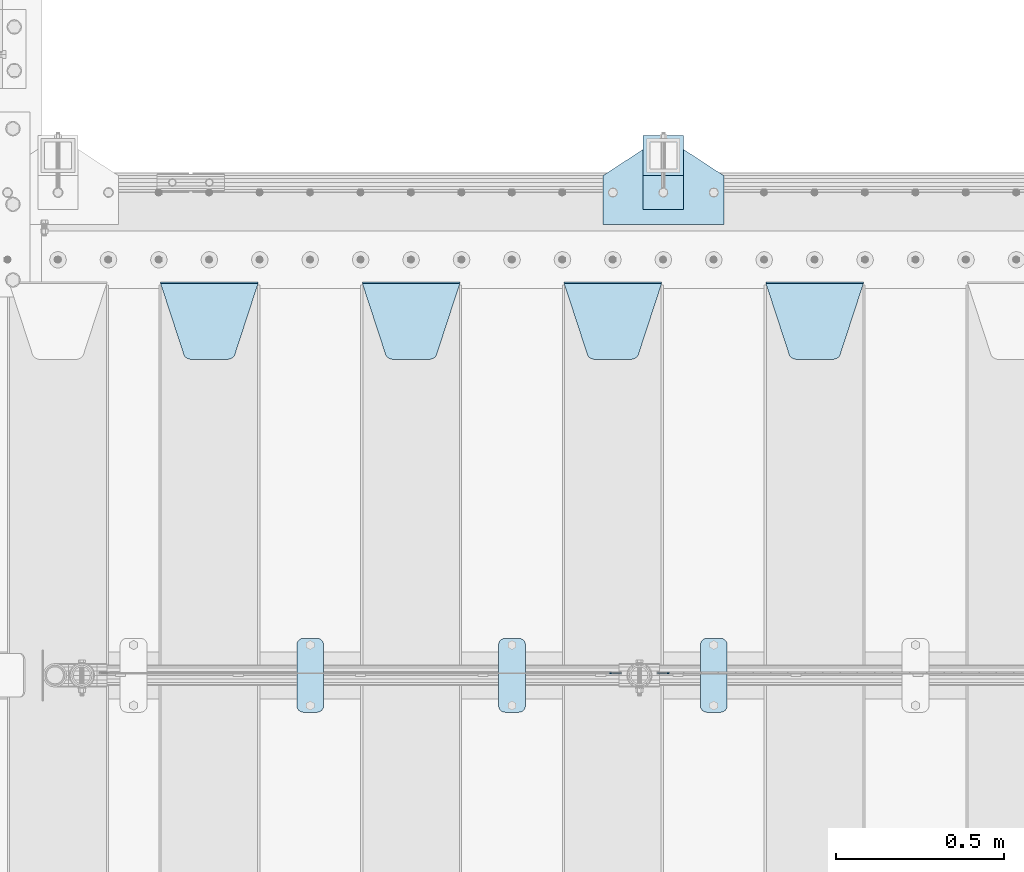
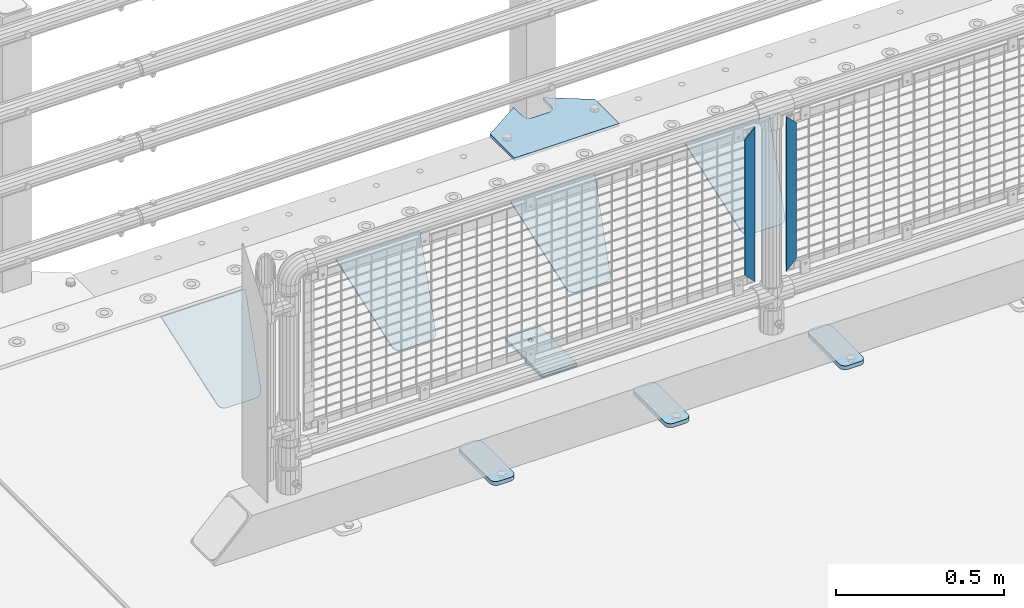
# One storey, part 194 of 219: 12 plates.
"""IFC2X3 building model written with IfcOpenShell, lengths in millimetres."""

from ifc_helpers import new_model, si_unit, frame, origin_with_axes, place, context, subcontext, project, spatial, faceted_brep, material, type_object, element, save


model = new_model("IFC2X3")

# Units and contexts
model_context = context("Model", 3, precision=1e-05, world=origin_with_axes())
body_context = subcontext(model_context, "Body", "Model", "MODEL_VIEW")
ifc_project = project(units=[si_unit("LENGTHUNIT", "METRE", prefix="MILLI"), si_unit("AREAUNIT", "SQUARE_METRE"), si_unit("VOLUMEUNIT", "CUBIC_METRE"), si_unit("MASSUNIT", "GRAM", prefix="KILO"), si_unit("TIMEUNIT", "SECOND"), si_unit("PLANEANGLEUNIT", "RADIAN"), si_unit("SOLIDANGLEUNIT", "STERADIAN"), si_unit("THERMODYNAMICTEMPERATUREUNIT", "DEGREE_CELSIUS"), si_unit("LUMINOUSINTENSITYUNIT", "LUMEN")], contexts=[model_context])

# Site, building, storey
site_placement = place(None, origin_with_axes())
site = spatial("IfcSite", under=ifc_project, at=site_placement, CompositionType="ELEMENT")
building_placement = place(site_placement, origin_with_axes())
building = spatial("IfcBuilding", under=site, at=building_placement, Name="Standard", CompositionType="ELEMENT")
storey_placement = place(building_placement, origin_with_axes())
storey = spatial("IfcBuildingStorey", under=building, at=storey_placement, Name="Undefined", CompositionType="ELEMENT", Elevation=0.0)

# Plates
ifc_material_1 = material(Name="STEEL/S355N")
plate_type_1 = type_object("IfcPlateType", PredefinedType="NOTDEFINED")
plate_1_placement = place(storey_placement, frame((2655.0, 32831.767766956, -1.76776695296758), z_axis=(0.0, -0.707106781186547, -0.707106781186548), x_axis=(1.0, 0.0, 0.0)))
element("IfcPlate", 1, at=plate_1_placement, inside=storey, type_object=plate_type_1, material=ifc_material_1, context=body_context, shape_type="Brep", body=[
    faceted_brep([(0.0, -2.5, 0.0), (69.345504679477, -2.5, 300.171731424834), (69.345504679477, 2.49999999999636, 300.171731424831), (0.0, 2.5, 0.0), (70.9274061199576, -2.50000000000364, 304.8974424154), (70.9274061199576, 2.49999999999636, 304.8974424154), (73.3818627772307, -2.50000000000364, 309.234538108532), (73.3818627772307, 2.49999999999636, 309.234538108532), (76.6187032999569, -2.50000000000364, 313.023683126106), (76.6187032999569, 2.49999999999636, 313.023683126106), (80.5190132704993, -2.50000000000364, 316.125672595372), (80.5190132704993, 2.49999999999636, 316.125672595372), (84.9395038596831, -2.50000000000364, 318.426546230476), (84.9395038596831, 2.5, 318.426546230479), (89.7177759439237, -2.50000000000364, 319.841774983277), (89.7177759439237, 2.5, 319.841774983281), (94.6782862926502, -2.50000000000364, 320.319366455078), (94.6782862926502, 2.49999999999636, 320.319366455078), (195.32171370735, -2.50000000000364, 320.319366455078), (195.32171370735, 2.49999999999636, 320.319366455078), (200.282224056076, -2.50000000000364, 319.841774983277), (200.282224056076, 2.5, 319.841774983281), (205.060496140317, -2.50000000000364, 318.426546230476), (205.060496140317, 2.49999999999636, 318.426546230476), (209.480986729501, -2.50000000000364, 316.125672595372), (209.480986729501, 2.49999999999636, 316.125672595372), (213.381296700043, -2.50000000000364, 313.023683126106), (213.381296700043, 2.49999999999272, 313.023683126106), (216.618137222769, -2.50000000000364, 309.234538108529), (216.618137222769, 2.49999999999636, 309.234538108525), (219.072593880042, -2.50000000000364, 304.8974424154), (219.072593880042, 2.49999999999636, 304.8974424154), (220.654495320523, -2.5, 300.171731424834), (220.654495320523, 2.49999999999636, 300.171731424831), (290.0, -2.50000000000364, 3.63797880709171e-12), (290.0, 2.49999999999636, 0.0)], [[[0, 1, 2, 3]], [[1, 4, 5, 2]], [[4, 6, 7, 5]], [[6, 8, 9, 7]], [[8, 10, 11, 9]], [[10, 12, 13, 11]], [[12, 14, 15, 13]], [[14, 16, 17, 15]], [[16, 18, 19, 17]], [[18, 20, 21, 19]], [[20, 22, 23, 21]], [[22, 24, 25, 23]], [[24, 26, 27, 25]], [[26, 28, 29, 27]], [[28, 30, 31, 29]], [[30, 32, 33, 31]], [[32, 34, 35, 33]], [[34, 0, 3, 35]], [[5, 7, 9, 11, 13, 15, 17, 19, 21, 23, 25, 27, 29, 31, 33, 35, 3, 2]], [[34, 32, 30, 28, 26, 24, 22, 20, 18, 16, 14, 12, 10, 8, 6, 4, 1, 0]]]),
])
plate_2_placement = place(storey_placement, frame((2055.0, 32831.767766956, -1.76776695296758), z_axis=(0.0, -0.707106781186547, -0.707106781186548), x_axis=(1.0, 0.0, 0.0)))
element("IfcPlate", 2, at=plate_2_placement, inside=storey, type_object=plate_type_1, material=ifc_material_1, context=body_context, shape_type="Brep", body=[
    faceted_brep([(0.0, -2.5, 0.0), (69.345504679477, -2.5, 300.171731424834), (69.345504679477, 2.49999999999636, 300.171731424831), (0.0, 2.5, 0.0), (70.9274061199576, -2.50000000000364, 304.8974424154), (70.9274061199576, 2.49999999999636, 304.8974424154), (73.3818627772307, -2.50000000000364, 309.234538108532), (73.3818627772307, 2.49999999999636, 309.234538108532), (76.6187032999569, -2.50000000000364, 313.023683126106), (76.6187032999569, 2.49999999999636, 313.023683126106), (80.5190132704993, -2.50000000000364, 316.125672595372), (80.5190132704993, 2.49999999999636, 316.125672595372), (84.9395038596831, -2.50000000000364, 318.426546230476), (84.9395038596831, 2.5, 318.426546230479), (89.7177759439237, -2.50000000000364, 319.841774983277), (89.7177759439237, 2.5, 319.841774983281), (94.6782862926502, -2.50000000000364, 320.319366455078), (94.6782862926502, 2.49999999999636, 320.319366455078), (195.32171370735, -2.50000000000364, 320.319366455078), (195.32171370735, 2.49999999999636, 320.319366455078), (200.282224056076, -2.50000000000364, 319.841774983277), (200.282224056076, 2.5, 319.841774983281), (205.060496140317, -2.50000000000364, 318.426546230476), (205.060496140317, 2.49999999999636, 318.426546230476), (209.480986729501, -2.50000000000364, 316.125672595372), (209.480986729501, 2.49999999999636, 316.125672595372), (213.381296700043, -2.50000000000364, 313.023683126106), (213.381296700043, 2.49999999999272, 313.023683126106), (216.618137222769, -2.50000000000364, 309.234538108529), (216.618137222769, 2.49999999999636, 309.234538108525), (219.072593880042, -2.50000000000364, 304.8974424154), (219.072593880042, 2.49999999999636, 304.8974424154), (220.654495320523, -2.5, 300.171731424834), (220.654495320523, 2.49999999999636, 300.171731424831), (290.0, -2.50000000000364, 3.63797880709171e-12), (290.0, 2.49999999999636, 0.0)], [[[0, 1, 2, 3]], [[1, 4, 5, 2]], [[4, 6, 7, 5]], [[6, 8, 9, 7]], [[8, 10, 11, 9]], [[10, 12, 13, 11]], [[12, 14, 15, 13]], [[14, 16, 17, 15]], [[16, 18, 19, 17]], [[18, 20, 21, 19]], [[20, 22, 23, 21]], [[22, 24, 25, 23]], [[24, 26, 27, 25]], [[26, 28, 29, 27]], [[28, 30, 31, 29]], [[30, 32, 33, 31]], [[32, 34, 35, 33]], [[34, 0, 3, 35]], [[5, 7, 9, 11, 13, 15, 17, 19, 21, 23, 25, 27, 29, 31, 33, 35, 3, 2]], [[34, 32, 30, 28, 26, 24, 22, 20, 18, 16, 14, 12, 10, 8, 6, 4, 1, 0]]]),
])
plate_3_placement = place(storey_placement, frame((1455.0, 32831.767766956, -1.76776695296758), z_axis=(0.0, -0.707106781186547, -0.707106781186548), x_axis=(1.0, 0.0, 0.0)))
element("IfcPlate", 3, at=plate_3_placement, inside=storey, type_object=plate_type_1, material=ifc_material_1, context=body_context, shape_type="Brep", body=[
    faceted_brep([(0.0, -2.5, 0.0), (69.345504679477, -2.5, 300.171731424834), (69.345504679477, 2.49999999999636, 300.171731424831), (0.0, 2.5, 0.0), (70.9274061199576, -2.50000000000364, 304.8974424154), (70.9274061199576, 2.49999999999636, 304.8974424154), (73.3818627772307, -2.50000000000364, 309.234538108532), (73.3818627772307, 2.49999999999636, 309.234538108532), (76.6187032999569, -2.50000000000364, 313.023683126106), (76.6187032999569, 2.49999999999636, 313.023683126106), (80.5190132704993, -2.50000000000364, 316.125672595372), (80.5190132704993, 2.49999999999636, 316.125672595372), (84.9395038596831, -2.50000000000364, 318.426546230476), (84.9395038596831, 2.5, 318.426546230479), (89.7177759439237, -2.50000000000364, 319.841774983277), (89.7177759439237, 2.5, 319.841774983281), (94.6782862926502, -2.50000000000364, 320.319366455078), (94.6782862926502, 2.49999999999636, 320.319366455078), (195.32171370735, -2.50000000000364, 320.319366455078), (195.32171370735, 2.49999999999636, 320.319366455078), (200.282224056076, -2.50000000000364, 319.841774983277), (200.282224056076, 2.5, 319.841774983281), (205.060496140317, -2.50000000000364, 318.426546230476), (205.060496140317, 2.49999999999636, 318.426546230476), (209.480986729501, -2.50000000000364, 316.125672595372), (209.480986729501, 2.49999999999636, 316.125672595372), (213.381296700043, -2.50000000000364, 313.023683126106), (213.381296700043, 2.49999999999272, 313.023683126106), (216.618137222769, -2.50000000000364, 309.234538108529), (216.618137222769, 2.49999999999636, 309.234538108525), (219.072593880042, -2.50000000000364, 304.8974424154), (219.072593880042, 2.49999999999636, 304.8974424154), (220.654495320523, -2.5, 300.171731424834), (220.654495320523, 2.49999999999636, 300.171731424831), (290.0, -2.50000000000364, 3.63797880709171e-12), (290.0, 2.49999999999636, 0.0)], [[[0, 1, 2, 3]], [[1, 4, 5, 2]], [[4, 6, 7, 5]], [[6, 8, 9, 7]], [[8, 10, 11, 9]], [[10, 12, 13, 11]], [[12, 14, 15, 13]], [[14, 16, 17, 15]], [[16, 18, 19, 17]], [[18, 20, 21, 19]], [[20, 22, 23, 21]], [[22, 24, 25, 23]], [[24, 26, 27, 25]], [[26, 28, 29, 27]], [[28, 30, 31, 29]], [[30, 32, 33, 31]], [[32, 34, 35, 33]], [[34, 0, 3, 35]], [[5, 7, 9, 11, 13, 15, 17, 19, 21, 23, 25, 27, 29, 31, 33, 35, 3, 2]], [[34, 32, 30, 28, 26, 24, 22, 20, 18, 16, 14, 12, 10, 8, 6, 4, 1, 0]]]),
])
plate_4_placement = place(storey_placement, frame((855.0, 32831.767766956, -1.76776695296758), z_axis=(0.0, -0.707106781186547, -0.707106781186548), x_axis=(1.0, 0.0, 0.0)))
element("IfcPlate", 4, at=plate_4_placement, inside=storey, type_object=plate_type_1, material=ifc_material_1, context=body_context, shape_type="Brep", body=[
    faceted_brep([(0.0, -2.5, 0.0), (69.345504679477, -2.5, 300.171731424834), (69.345504679477, 2.49999999999636, 300.171731424831), (0.0, 2.5, 0.0), (70.9274061199576, -2.50000000000364, 304.8974424154), (70.9274061199576, 2.49999999999636, 304.8974424154), (73.3818627772307, -2.50000000000364, 309.234538108532), (73.3818627772307, 2.49999999999636, 309.234538108532), (76.6187032999569, -2.50000000000364, 313.023683126106), (76.6187032999569, 2.49999999999636, 313.023683126106), (80.5190132704993, -2.50000000000364, 316.125672595372), (80.5190132704993, 2.49999999999636, 316.125672595372), (84.9395038596831, -2.50000000000364, 318.426546230476), (84.9395038596831, 2.5, 318.426546230479), (89.7177759439237, -2.50000000000364, 319.841774983277), (89.7177759439237, 2.5, 319.841774983281), (94.6782862926502, -2.50000000000364, 320.319366455078), (94.6782862926502, 2.49999999999636, 320.319366455078), (195.32171370735, -2.50000000000364, 320.319366455078), (195.32171370735, 2.49999999999636, 320.319366455078), (200.282224056076, -2.50000000000364, 319.841774983277), (200.282224056076, 2.5, 319.841774983281), (205.060496140317, -2.50000000000364, 318.426546230476), (205.060496140317, 2.49999999999636, 318.426546230476), (209.480986729501, -2.50000000000364, 316.125672595372), (209.480986729501, 2.49999999999636, 316.125672595372), (213.381296700043, -2.50000000000364, 313.023683126106), (213.381296700043, 2.49999999999272, 313.023683126106), (216.618137222769, -2.50000000000364, 309.234538108529), (216.618137222769, 2.49999999999636, 309.234538108525), (219.072593880042, -2.50000000000364, 304.8974424154), (219.072593880042, 2.49999999999636, 304.8974424154), (220.654495320523, -2.5, 300.171731424834), (220.654495320523, 2.49999999999636, 300.171731424831), (290.0, -2.50000000000364, 3.63797880709171e-12), (290.0, 2.49999999999636, 0.0)], [[[0, 1, 2, 3]], [[1, 4, 5, 2]], [[4, 6, 7, 5]], [[6, 8, 9, 7]], [[8, 10, 11, 9]], [[10, 12, 13, 11]], [[12, 14, 15, 13]], [[14, 16, 17, 15]], [[16, 18, 19, 17]], [[18, 20, 21, 19]], [[20, 22, 23, 21]], [[22, 24, 25, 23]], [[24, 26, 27, 25]], [[26, 28, 29, 27]], [[28, 30, 31, 29]], [[30, 32, 33, 31]], [[32, 34, 35, 33]], [[34, 0, 3, 35]], [[5, 7, 9, 11, 13, 15, 17, 19, 21, 23, 25, 27, 29, 31, 33, 35, 3, 2]], [[34, 32, 30, 28, 26, 24, 22, 20, 18, 16, 14, 12, 10, 8, 6, 4, 1, 0]]]),
])
ifc_material_2 = material(Name="Misc_Undefined")
plate_type_2 = type_object("IfcPlateType", PredefinedType="NOTDEFINED")
plate_5_placement = place(storey_placement, frame((2367.50971354097, 31670.5, 879.519963133601), z_axis=(-0.707008801899319, 0.0, -0.707204746899291), x_axis=(-0.707204746899285, 0.0, 0.707008801899324)))
element("IfcPlate", 5, at=plate_5_placement, inside=storey, type_object=plate_type_2, material=ifc_material_2, context=body_context, shape_type="Brep", body=[
    faceted_brep([(0.0, -1.5, -5.6843418860808e-14), (-348.552185058593, -1.5, 348.655029296875), (-348.552185058593, 1.5, 348.655029296875), (0.0, 1.5, -5.6843418860808e-14), (-348.544891357421, -1.5, 398.152496337892), (-348.544891357421, 1.5, 398.152496337892), (49.5043945312482, -1.5, 7.6397554948926e-11), (49.5043945312482, 1.5, 7.6397554948926e-11)], [[[0, 1, 2, 3]], [[1, 4, 5, 2]], [[4, 6, 7, 5]], [[6, 0, 3, 7]], [[5, 7, 3, 2]], [[6, 4, 1, 0]]]),
])
plate_6_placement = place(storey_placement, frame((2190.49968748361, 31670.5, 879.52), z_axis=(0.707103624179499, 0.0, -0.707109938179501), x_axis=(0.707109938179499, 0.0, 0.707103624179502)))
element("IfcPlate", 6, at=plate_6_placement, inside=storey, type_object=plate_type_2, material=ifc_material_2, context=body_context, shape_type="Brep", body=[
    faceted_brep([(0.0, -1.5, -5.6843418860808e-14), (-348.605163574219, -1.5, 348.602081298829), (-348.605163574219, 1.5, 348.602081298829), (0.0, 1.5, -5.6843418860808e-14), (-348.605163574217, -1.5, 398.0993347168), (-348.605163574217, 1.5, 398.0993347168), (49.4976959228516, -1.5, -1.0550138540566e-10), (49.4976959228516, 1.5, -1.0550138540566e-10)], [[[0, 1, 2, 3]], [[1, 4, 5, 2]], [[4, 6, 7, 5]], [[6, 0, 3, 7]], [[5, 7, 3, 2]], [[6, 4, 1, 0]]]),
])
ifc_material_3 = material(Name="STEEL/S355J2")
plate_type_3 = type_object("IfcPlateType", PredefinedType="NOTDEFINED")
plate_7_placement = place(storey_placement, frame((2460.0, 31774.5, 21.0199999999977), z_axis=(1.0, 0.0, 0.0), x_axis=(0.0, -1.0, 0.0)))
element("IfcPlate", 7, at=plate_7_placement, inside=storey, type_object=plate_type_3, material=ifc_material_3, context=body_context, shape_type="Brep", body=[
    faceted_brep([(0.0, -7.0, 20.0), (0.0, -7.0, 60.0), (0.0, 7.0, 60.0), (0.0, 7.0, 20.0), (0.384294391937146, -7.0, 63.9018064403226), (0.384294391937146, 7.0, 63.9018064403226), (1.52240934977453, -7.0, 67.6536686473009), (1.52240934977453, 7.0, 67.6536686473009), (3.37060775395003, -7.0, 71.1114046603925), (3.37060775395003, 7.0, 71.1114046603925), (5.8578643762703, -7.0, 74.1421356237315), (5.8578643762703, 7.0, 74.1421356237315), (8.88859533960931, -7.0, 76.6293922460518), (8.88859533960931, 7.0, 76.6293922460518), (12.3463313526991, -7.0, 78.4775906502255), (12.3463313526991, 7.0, 78.4775906502255), (16.0981935596792, -7.0, 79.6157056080647), (16.0981935596792, 7.0, 79.6157056080647), (20.0, -7.0, 80.0), (20.0, 7.0, 80.0), (200.0, -7.0, 80.0), (200.0, 7.0, 80.0), (203.901806440321, -7.0, 79.6157056080647), (203.901806440321, 7.0, 79.6157056080647), (207.653668647301, -7.0, 78.4775906502255), (207.653668647301, 7.0, 78.4775906502255), (211.111404660391, -7.0, 76.6293922460518), (211.111404660391, 7.0, 76.6293922460518), (214.14213562373, -7.0, 74.1421356237315), (214.14213562373, 7.0, 74.1421356237315), (216.62939224605, -7.0, 71.1114046603925), (216.62939224605, 7.0, 71.1114046603925), (218.477590650225, -7.0, 67.6536686473009), (218.477590650225, 7.0, 67.6536686473009), (219.615705608063, -7.0, 63.9018064403226), (219.615705608063, 7.0, 63.9018064403226), (220.0, -7.0, 60.0), (220.0, 7.0, 60.0), (220.0, -7.0, 20.0), (220.0, 7.0, 20.0), (219.615705608063, -7.0, 16.0981935596774), (219.615705608063, 7.0, 16.0981935596774), (218.477590650225, -7.0, 12.3463313526991), (218.477590650225, 7.0, 12.3463313526991), (216.62939224605, -7.0, 8.88859533960749), (216.62939224605, 7.0, 8.88859533960749), (214.14213562373, -7.0, 5.85786437626848), (214.14213562373, 7.0, 5.85786437626848), (211.111404660391, -7.0, 3.37060775394821), (211.111404660391, 7.0, 3.37060775394821), (207.653668647301, -7.0, 1.52240934977453), (207.653668647301, 7.0, 1.52240934977453), (203.901806440321, -7.0, 0.384294391935327), (203.901806440321, 7.0, 0.384294391935327), (200.0, -7.0, 0.0), (200.0, 7.0, 0.0), (20.0, -7.0, 0.0), (20.0, 7.0, 0.0), (16.0981935596792, -7.0, 0.384294391935327), (16.0981935596792, 7.0, 0.384294391935327), (12.3463313526991, -7.0, 1.52240934977453), (12.3463313526991, 7.0, 1.52240934977453), (8.88859533960931, -7.0, 3.37060775394821), (8.88859533960931, 7.0, 3.37060775394821), (5.8578643762703, -7.0, 5.85786437626848), (5.8578643762703, 7.0, 5.85786437626848), (3.37060775395003, -7.0, 8.88859533960749), (3.37060775395003, 7.0, 8.88859533960749), (1.52240934977453, -7.0, 12.3463313526991), (1.52240934977453, 7.0, 12.3463313526991), (0.384294391937146, -7.0, 16.0981935596774), (0.384294391937146, 7.0, 16.0981935596774)], [[[0, 1, 2, 3]], [[1, 4, 5, 2]], [[4, 6, 7, 5]], [[6, 8, 9, 7]], [[8, 10, 11, 9]], [[10, 12, 13, 11]], [[12, 14, 15, 13]], [[14, 16, 17, 15]], [[16, 18, 19, 17]], [[18, 20, 21, 19]], [[20, 22, 23, 21]], [[22, 24, 25, 23]], [[24, 26, 27, 25]], [[26, 28, 29, 27]], [[28, 30, 31, 29]], [[30, 32, 33, 31]], [[32, 34, 35, 33]], [[34, 36, 37, 35]], [[36, 38, 39, 37]], [[38, 40, 41, 39]], [[40, 42, 43, 41]], [[42, 44, 45, 43]], [[44, 46, 47, 45]], [[46, 48, 49, 47]], [[48, 50, 51, 49]], [[50, 52, 53, 51]], [[52, 54, 55, 53]], [[54, 56, 57, 55]], [[56, 58, 59, 57]], [[58, 60, 61, 59]], [[60, 62, 63, 61]], [[62, 64, 65, 63]], [[64, 66, 67, 65]], [[66, 68, 69, 67]], [[68, 70, 71, 69]], [[70, 0, 3, 71]], [[5, 7, 9, 11, 13, 15, 17, 19, 21, 23, 25, 27, 29, 31, 33, 35, 37, 39, 41, 43, 45, 47, 49, 51, 53, 55, 57, 59, 61, 63, 65, 67, 69, 71, 3, 2]], [[70, 68, 66, 64, 62, 60, 58, 56, 54, 52, 50, 48, 46, 44, 42, 40, 38, 36, 34, 32, 30, 28, 26, 24, 22, 20, 18, 16, 14, 12, 10, 8, 6, 4, 1, 0]]]),
])
plate_8_placement = place(storey_placement, frame((1860.0, 31774.5, 21.0199999999977), z_axis=(1.0, 0.0, 0.0), x_axis=(0.0, -1.0, 0.0)))
element("IfcPlate", 8, at=plate_8_placement, inside=storey, type_object=plate_type_3, material=ifc_material_3, context=body_context, shape_type="Brep", body=[
    faceted_brep([(0.0, -7.0, 20.0), (0.0, -7.0, 60.0), (0.0, 7.0, 60.0), (0.0, 7.0, 20.0), (0.384294391937146, -7.0, 63.9018064403226), (0.384294391937146, 7.0, 63.9018064403226), (1.52240934977453, -7.0, 67.6536686473009), (1.52240934977453, 7.0, 67.6536686473009), (3.37060775395003, -7.0, 71.1114046603925), (3.37060775395003, 7.0, 71.1114046603925), (5.8578643762703, -7.0, 74.1421356237315), (5.8578643762703, 7.0, 74.1421356237315), (8.88859533960931, -7.0, 76.6293922460518), (8.88859533960931, 7.0, 76.6293922460518), (12.3463313526991, -7.0, 78.4775906502255), (12.3463313526991, 7.0, 78.4775906502255), (16.0981935596792, -7.0, 79.6157056080647), (16.0981935596792, 7.0, 79.6157056080647), (20.0, -7.0, 80.0), (20.0, 7.0, 80.0), (200.0, -7.0, 80.0), (200.0, 7.0, 80.0), (203.901806440321, -7.0, 79.6157056080647), (203.901806440321, 7.0, 79.6157056080647), (207.653668647301, -7.0, 78.4775906502255), (207.653668647301, 7.0, 78.4775906502255), (211.111404660391, -7.0, 76.6293922460518), (211.111404660391, 7.0, 76.6293922460518), (214.14213562373, -7.0, 74.1421356237315), (214.14213562373, 7.0, 74.1421356237315), (216.62939224605, -7.0, 71.1114046603925), (216.62939224605, 7.0, 71.1114046603925), (218.477590650225, -7.0, 67.6536686473009), (218.477590650225, 7.0, 67.6536686473009), (219.615705608063, -7.0, 63.9018064403226), (219.615705608063, 7.0, 63.9018064403226), (220.0, -7.0, 60.0), (220.0, 7.0, 60.0), (220.0, -7.0, 20.0), (220.0, 7.0, 20.0), (219.615705608063, -7.0, 16.0981935596774), (219.615705608063, 7.0, 16.0981935596774), (218.477590650225, -7.0, 12.3463313526991), (218.477590650225, 7.0, 12.3463313526991), (216.62939224605, -7.0, 8.88859533960749), (216.62939224605, 7.0, 8.88859533960749), (214.14213562373, -7.0, 5.85786437626848), (214.14213562373, 7.0, 5.85786437626848), (211.111404660391, -7.0, 3.37060775394821), (211.111404660391, 7.0, 3.37060775394821), (207.653668647301, -7.0, 1.52240934977453), (207.653668647301, 7.0, 1.52240934977453), (203.901806440321, -7.0, 0.384294391935327), (203.901806440321, 7.0, 0.384294391935327), (200.0, -7.0, 0.0), (200.0, 7.0, 0.0), (20.0, -7.0, 0.0), (20.0, 7.0, 0.0), (16.0981935596792, -7.0, 0.384294391935327), (16.0981935596792, 7.0, 0.384294391935327), (12.3463313526991, -7.0, 1.52240934977453), (12.3463313526991, 7.0, 1.52240934977453), (8.88859533960931, -7.0, 3.37060775394821), (8.88859533960931, 7.0, 3.37060775394821), (5.8578643762703, -7.0, 5.85786437626848), (5.8578643762703, 7.0, 5.85786437626848), (3.37060775395003, -7.0, 8.88859533960749), (3.37060775395003, 7.0, 8.88859533960749), (1.52240934977453, -7.0, 12.3463313526991), (1.52240934977453, 7.0, 12.3463313526991), (0.384294391937146, -7.0, 16.0981935596774), (0.384294391937146, 7.0, 16.0981935596774)], [[[0, 1, 2, 3]], [[1, 4, 5, 2]], [[4, 6, 7, 5]], [[6, 8, 9, 7]], [[8, 10, 11, 9]], [[10, 12, 13, 11]], [[12, 14, 15, 13]], [[14, 16, 17, 15]], [[16, 18, 19, 17]], [[18, 20, 21, 19]], [[20, 22, 23, 21]], [[22, 24, 25, 23]], [[24, 26, 27, 25]], [[26, 28, 29, 27]], [[28, 30, 31, 29]], [[30, 32, 33, 31]], [[32, 34, 35, 33]], [[34, 36, 37, 35]], [[36, 38, 39, 37]], [[38, 40, 41, 39]], [[40, 42, 43, 41]], [[42, 44, 45, 43]], [[44, 46, 47, 45]], [[46, 48, 49, 47]], [[48, 50, 51, 49]], [[50, 52, 53, 51]], [[52, 54, 55, 53]], [[54, 56, 57, 55]], [[56, 58, 59, 57]], [[58, 60, 61, 59]], [[60, 62, 63, 61]], [[62, 64, 65, 63]], [[64, 66, 67, 65]], [[66, 68, 69, 67]], [[68, 70, 71, 69]], [[70, 0, 3, 71]], [[5, 7, 9, 11, 13, 15, 17, 19, 21, 23, 25, 27, 29, 31, 33, 35, 37, 39, 41, 43, 45, 47, 49, 51, 53, 55, 57, 59, 61, 63, 65, 67, 69, 71, 3, 2]], [[70, 68, 66, 64, 62, 60, 58, 56, 54, 52, 50, 48, 46, 44, 42, 40, 38, 36, 34, 32, 30, 28, 26, 24, 22, 20, 18, 16, 14, 12, 10, 8, 6, 4, 1, 0]]]),
])
plate_9_placement = place(storey_placement, frame((1260.0, 31774.5, 21.0199999999977), z_axis=(1.0, 0.0, 0.0), x_axis=(0.0, -1.0, 0.0)))
element("IfcPlate", 9, at=plate_9_placement, inside=storey, type_object=plate_type_3, material=ifc_material_3, context=body_context, shape_type="Brep", body=[
    faceted_brep([(0.0, -7.0, 20.0), (0.0, -7.0, 60.0), (0.0, 7.0, 60.0), (0.0, 7.0, 20.0), (0.384294391937146, -7.0, 63.9018064403226), (0.384294391937146, 7.0, 63.9018064403226), (1.52240934977453, -7.0, 67.6536686473009), (1.52240934977453, 7.0, 67.6536686473009), (3.37060775395003, -7.0, 71.1114046603925), (3.37060775395003, 7.0, 71.1114046603925), (5.8578643762703, -7.0, 74.1421356237315), (5.8578643762703, 7.0, 74.1421356237315), (8.88859533960931, -7.0, 76.6293922460518), (8.88859533960931, 7.0, 76.6293922460518), (12.3463313526991, -7.0, 78.4775906502255), (12.3463313526991, 7.0, 78.4775906502255), (16.0981935596792, -7.0, 79.6157056080647), (16.0981935596792, 7.0, 79.6157056080647), (20.0, -7.0, 80.0), (20.0, 7.0, 80.0), (200.0, -7.0, 80.0), (200.0, 7.0, 80.0), (203.901806440321, -7.0, 79.6157056080647), (203.901806440321, 7.0, 79.6157056080647), (207.653668647301, -7.0, 78.4775906502255), (207.653668647301, 7.0, 78.4775906502255), (211.111404660391, -7.0, 76.6293922460518), (211.111404660391, 7.0, 76.6293922460518), (214.14213562373, -7.0, 74.1421356237315), (214.14213562373, 7.0, 74.1421356237315), (216.62939224605, -7.0, 71.1114046603925), (216.62939224605, 7.0, 71.1114046603925), (218.477590650225, -7.0, 67.6536686473009), (218.477590650225, 7.0, 67.6536686473009), (219.615705608063, -7.0, 63.9018064403226), (219.615705608063, 7.0, 63.9018064403226), (220.0, -7.0, 60.0), (220.0, 7.0, 60.0), (220.0, -7.0, 20.0), (220.0, 7.0, 20.0), (219.615705608063, -7.0, 16.0981935596774), (219.615705608063, 7.0, 16.0981935596774), (218.477590650225, -7.0, 12.3463313526991), (218.477590650225, 7.0, 12.3463313526991), (216.62939224605, -7.0, 8.88859533960749), (216.62939224605, 7.0, 8.88859533960749), (214.14213562373, -7.0, 5.85786437626848), (214.14213562373, 7.0, 5.85786437626848), (211.111404660391, -7.0, 3.37060775394821), (211.111404660391, 7.0, 3.37060775394821), (207.653668647301, -7.0, 1.52240934977453), (207.653668647301, 7.0, 1.52240934977453), (203.901806440321, -7.0, 0.384294391935327), (203.901806440321, 7.0, 0.384294391935327), (200.0, -7.0, 0.0), (200.0, 7.0, 0.0), (20.0, -7.0, 0.0), (20.0, 7.0, 0.0), (16.0981935596792, -7.0, 0.384294391935327), (16.0981935596792, 7.0, 0.384294391935327), (12.3463313526991, -7.0, 1.52240934977453), (12.3463313526991, 7.0, 1.52240934977453), (8.88859533960931, -7.0, 3.37060775394821), (8.88859533960931, 7.0, 3.37060775394821), (5.8578643762703, -7.0, 5.85786437626848), (5.8578643762703, 7.0, 5.85786437626848), (3.37060775395003, -7.0, 8.88859533960749), (3.37060775395003, 7.0, 8.88859533960749), (1.52240934977453, -7.0, 12.3463313526991), (1.52240934977453, 7.0, 12.3463313526991), (0.384294391937146, -7.0, 16.0981935596774), (0.384294391937146, 7.0, 16.0981935596774)], [[[0, 1, 2, 3]], [[1, 4, 5, 2]], [[4, 6, 7, 5]], [[6, 8, 9, 7]], [[8, 10, 11, 9]], [[10, 12, 13, 11]], [[12, 14, 15, 13]], [[14, 16, 17, 15]], [[16, 18, 19, 17]], [[18, 20, 21, 19]], [[20, 22, 23, 21]], [[22, 24, 25, 23]], [[24, 26, 27, 25]], [[26, 28, 29, 27]], [[28, 30, 31, 29]], [[30, 32, 33, 31]], [[32, 34, 35, 33]], [[34, 36, 37, 35]], [[36, 38, 39, 37]], [[38, 40, 41, 39]], [[40, 42, 43, 41]], [[42, 44, 45, 43]], [[44, 46, 47, 45]], [[46, 48, 49, 47]], [[48, 50, 51, 49]], [[50, 52, 53, 51]], [[52, 54, 55, 53]], [[54, 56, 57, 55]], [[56, 58, 59, 57]], [[58, 60, 61, 59]], [[60, 62, 63, 61]], [[62, 64, 65, 63]], [[64, 66, 67, 65]], [[66, 68, 69, 67]], [[68, 70, 71, 69]], [[70, 0, 3, 71]], [[5, 7, 9, 11, 13, 15, 17, 19, 21, 23, 25, 27, 29, 31, 33, 35, 37, 39, 41, 43, 45, 47, 49, 51, 53, 55, 57, 59, 61, 63, 65, 67, 69, 71, 3, 2]], [[70, 68, 66, 64, 62, 60, 58, 56, 54, 52, 50, 48, 46, 44, 42, 40, 38, 36, 34, 32, 30, 28, 26, 24, 22, 20, 18, 16, 14, 12, 10, 8, 6, 4, 1, 0]]]),
])
plate_type_4 = type_object("IfcPlateType", PredefinedType="NOTDEFINED")
plate_10_placement = place(storey_placement, frame((2170.0, 33005.0, 5.00000000004911), z_axis=(0.0, 1.0, 0.0), x_axis=(1.0, 0.0, 0.0)))
element("IfcPlate", 10, at=plate_10_placement, inside=storey, type_object=plate_type_4, material=ifc_material_3, context=body_context, shape_type="Brep", body=[
    faceted_brep([(0.0, -5.0, 0.0), (2.31396552408114e-06, -5.0, 145.0), (2.31396552408114e-06, 5.0, 145.0), (0.0, 5.0, 0.0), (130.0, -5.0, 230.0), (130.0, 5.0, 230.0), (130.0, -5.0, 180.0), (130.0, 5.0, 180.0), (130.48036798992, -5.0, 175.122741949599), (130.48036798992, 5.0, 175.122741949599), (131.903011687218, -5.0, 170.432914190875), (131.903011687218, 5.0, 170.432914190875), (134.213259692437, -5.0, 166.110744174512), (134.213259692437, 5.0, 166.110744174512), (137.322330470337, -5.0, 162.322330470335), (137.322330470337, 5.0, 162.322330470335), (141.11074417451, -5.0, 159.213259692435), (141.11074417451, 5.0, 159.213259692435), (145.432914190873, -5.0, 156.903011687216), (145.432914190873, 5.0, 156.903011687216), (150.122741949597, -5.0, 155.48036798992), (150.122741949597, 5.0, 155.48036798992), (155.0, -5.0, 155.0), (155.0, 5.0, 155.0), (205.0, -5.0, 155.0), (205.0, 5.0, 155.0), (209.877258050403, -5.0, 155.48036798992), (209.877258050403, 5.0, 155.48036798992), (214.567085809127, -5.0, 156.903011687216), (214.567085809127, 5.0, 156.903011687216), (218.88925582549, -5.0, 159.213259692435), (218.88925582549, 5.0, 159.213259692435), (222.677669529663, -5.0, 162.322330470335), (222.677669529663, 5.0, 162.322330470335), (225.786740307563, -5.0, 166.110744174512), (225.786740307563, 5.0, 166.110744174512), (228.096988312782, -5.0, 170.432914190875), (228.096988312782, 5.0, 170.432914190875), (229.51963201008, -5.0, 175.122741949599), (229.51963201008, 5.0, 175.122741949599), (230.0, -5.0, 180.0), (230.0, 5.0, 180.0), (230.0, -5.0, 230.0), (230.0, 5.0, 230.0), (360.0, -5.0, 145.0), (360.0, 5.0, 145.0), (360.0, -5.0, -7.27595761418343e-12), (360.0, 5.0, -7.27595761418343e-12)], [[[0, 1, 2, 3]], [[1, 4, 5, 2]], [[4, 6, 7, 5]], [[6, 8, 9, 7]], [[8, 10, 11, 9]], [[10, 12, 13, 11]], [[12, 14, 15, 13]], [[14, 16, 17, 15]], [[16, 18, 19, 17]], [[18, 20, 21, 19]], [[20, 22, 23, 21]], [[22, 24, 25, 23]], [[24, 26, 27, 25]], [[26, 28, 29, 27]], [[28, 30, 31, 29]], [[30, 32, 33, 31]], [[32, 34, 35, 33]], [[34, 36, 37, 35]], [[36, 38, 39, 37]], [[38, 40, 41, 39]], [[40, 42, 43, 41]], [[42, 44, 45, 43]], [[44, 46, 47, 45]], [[46, 0, 3, 47]], [[5, 7, 9, 11, 13, 15, 17, 19, 21, 23, 25, 27, 29, 31, 33, 35, 37, 39, 41, 43, 45, 47, 3, 2]], [[46, 44, 42, 40, 38, 36, 34, 32, 30, 28, 26, 24, 22, 20, 18, 16, 14, 12, 10, 8, 6, 4, 1, 0]]]),
])
plate_type_5 = type_object("IfcPlateType", PredefinedType="NOTDEFINED")
plate_11_placement = place(storey_placement, frame((2290.00000000014, 33050.0000000002, -850.000000000002), z_axis=(0.0, 1.0, 0.0), x_axis=(1.0, 0.0, 0.0)))
element("IfcPlate", 11, at=plate_11_placement, inside=storey, type_object=plate_type_5, material=ifc_material_3, context=body_context, shape_type="Brep", body=[
    faceted_brep([(66.3639610305399, -5.0, 163.636038969111), (66.3639610305399, 5.0, 163.636038969111), (59.9999999998618, 5.0, 160.999999999789), (59.9999999998618, -5.0, 160.999999999789), (53.6360389691836, 5.0, 163.636038969111), (53.6360389691836, -5.0, 163.636038969111), (50.9999999998618, 5.0, 169.999999999789), (50.9999999998618, -5.0, 169.999999999789), (53.6360389691836, 5.0, 176.363961030467), (53.6360389691836, -5.0, 176.363961030467), (59.9999999998618, 5.0, 178.999999999789), (59.9999999998618, -5.0, 178.999999999789), (66.3639610305399, 5.0, 176.363961030467), (66.3639610305399, -5.0, 176.363961030467), (68.9999999998618, 5.0, 169.999999999789), (68.9999999998618, -5.0, 169.999999999789), (120.0, -5.0, 0.0), (120.0, -5.0, 220.0), (0.0, -5.0, 220.0), (0.0, -5.0, 0.0), (0.0, 5.0, 0.0), (120.0, 5.0, 0.0), (120.0, 5.0, 220.0), (0.0, 5.0, 220.0)], [[[0, 1, 2, 3]], [[3, 2, 4, 5]], [[5, 4, 6, 7]], [[7, 6, 8, 9]], [[9, 8, 10, 11]], [[11, 10, 12, 13]], [[13, 12, 14, 15]], [[15, 14, 1, 0]], [[16, 17, 18, 19], [3, 5, 7, 9, 11, 13, 15, 0]], [[16, 19, 20, 21]], [[17, 16, 21, 22]], [[18, 17, 22, 23]], [[19, 18, 23, 20]], [[22, 21, 20, 23], [10, 8, 6, 4, 2, 1, 14, 12]]]),
])
plate_type_6 = type_object("IfcPlateType", PredefinedType="NOTDEFINED")
plate_12_placement = place(storey_placement, frame((2290.00000000014, 33050.0000000002, -857.500000000002), z_axis=(0.0, 1.0, 0.0), x_axis=(1.0, 0.0, 0.0)))
element("IfcPlate", 12, at=plate_12_placement, inside=storey, type_object=plate_type_6, material=ifc_material_3, context=body_context, shape_type="Brep", body=[
    faceted_brep([(0.0, -2.5, 0.0), (0.0, -2.5, 100.0), (0.0, 2.5, 100.0), (0.0, 2.5, 0.0), (120.0, -2.5, 100.0), (120.0, 2.5, 100.0), (120.0, -2.5, 0.0), (120.0, 2.5, 0.0)], [[[0, 1, 2, 3]], [[1, 4, 5, 2]], [[4, 6, 7, 5]], [[6, 0, 3, 7]], [[5, 7, 3, 2]], [[6, 4, 1, 0]]]),
])

save(model, "model.ifc")
